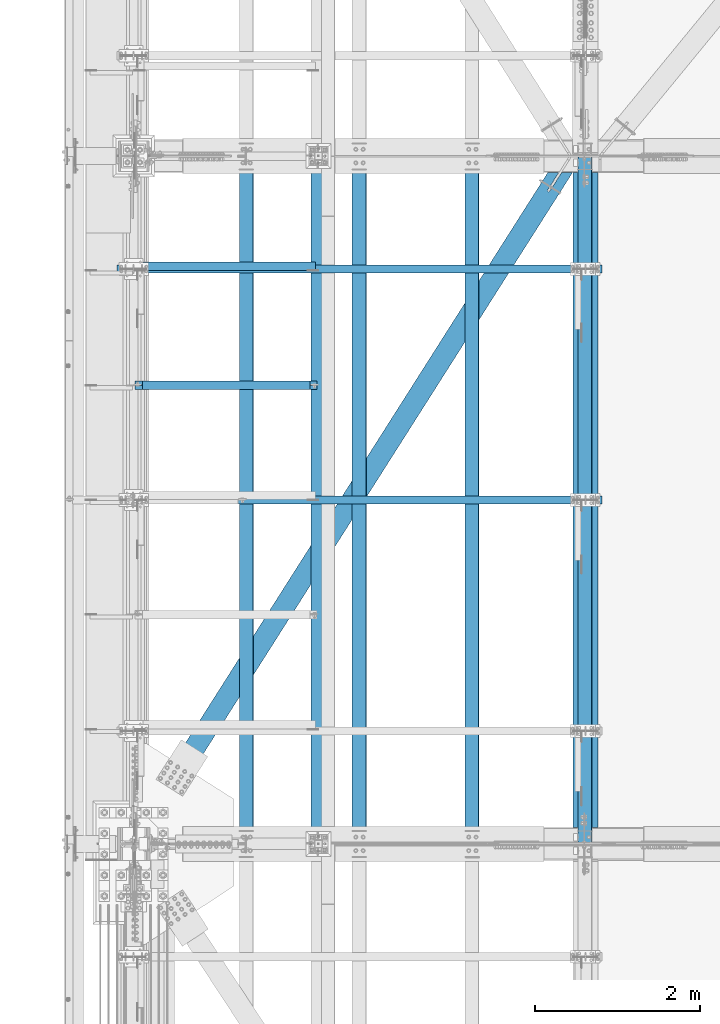
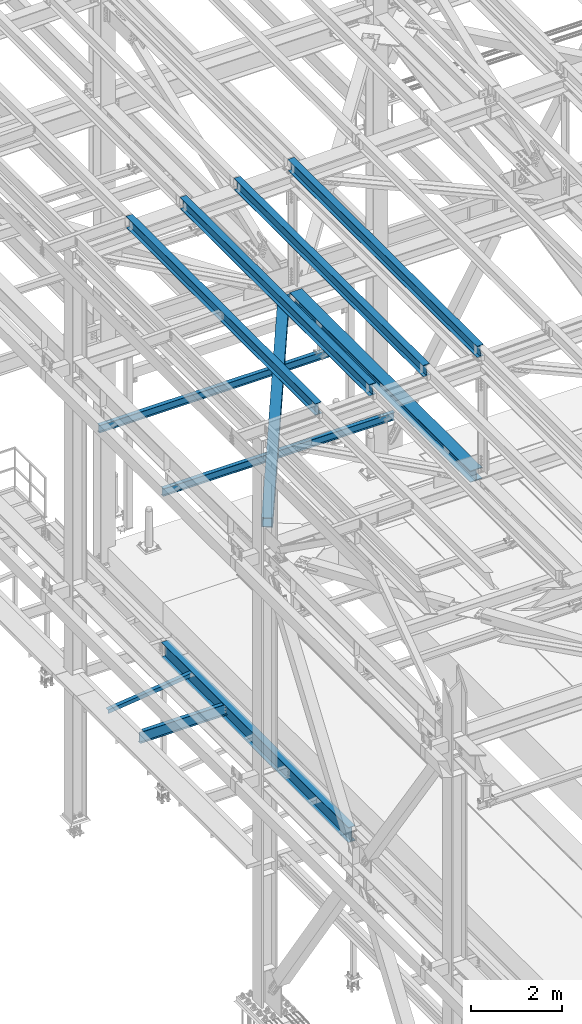
# One storey, part 1878 of 3843: 11 beams, 11 elements without a shape of their own.
"""IFC2X3 building model written with IfcOpenShell, lengths in millimetres."""

from ifc_helpers import new_model, si_unit, frame, origin_with_axes, place, context, subcontext, project, spatial, faceted_brep, material, type_object, element, aggregate, save


model = new_model("IFC2X3")

# Units and contexts
model_context = context("Model", 3, precision=1e-05, world=origin_with_axes())
body_context = subcontext(model_context, "Body", "Model", "MODEL_VIEW")
ifc_project = project(units=[si_unit("LENGTHUNIT", "METRE", prefix="MILLI"), si_unit("AREAUNIT", "SQUARE_METRE"), si_unit("VOLUMEUNIT", "CUBIC_METRE"), si_unit("MASSUNIT", "GRAM", prefix="KILO"), si_unit("TIMEUNIT", "SECOND"), si_unit("PLANEANGLEUNIT", "RADIAN"), si_unit("SOLIDANGLEUNIT", "STERADIAN"), si_unit("THERMODYNAMICTEMPERATUREUNIT", "DEGREE_CELSIUS"), si_unit("LUMINOUSINTENSITYUNIT", "LUMEN")], contexts=[model_context])

# Site, building, storey
site_placement = place(None, origin_with_axes())
site = spatial("IfcSite", under=ifc_project, at=site_placement, CompositionType="ELEMENT")
building_placement = place(site_placement, origin_with_axes())
building = spatial("IfcBuilding", under=site, at=building_placement, Name="Undefined", CompositionType="ELEMENT")
storey_placement = place(building_placement, origin_with_axes())
storey = spatial("IfcBuildingStorey", under=building, at=storey_placement, Name="Undefined", CompositionType="ELEMENT", Elevation=0.0)

# Assembly, beam
assembly_1_placement = place(storey_placement, origin_with_axes())
assembly_1 = element("IfcElementAssembly", 1, at=assembly_1_placement, inside=storey, Name="ANGLE", AssemblyPlace="NOTDEFINED", PredefinedType="RIGID_FRAME")
ifc_material_1 = material(Name="STEEL/A572-50")
beam_type_1 = type_object("IfcBeamType", Name="L4X4X3/8", PredefinedType="NOTDEFINED")
beam_1_placement = place(assembly_1_placement, frame((38788.5093206542, 82646.242188, 33960.1419503901), z_axis=(0.0, 1.0, 0.0), x_axis=(-0.993268693078032, 0.0, -0.115833084009098)))
beam_1 = element("IfcBeam", 2, at=beam_1_placement, type_object=beam_type_1, material=ifc_material_1, Name="ANGLE", ObjectType="L4X4X3/8", context=body_context, shape_type="Brep", body=[
    faceted_brep([(0.0, 50.8000000000029, -50.8000000000029), (0.0, 50.8000000000029, 50.8000000000029), (2192.8104802954, 50.7999999940694, 50.8000000000029), (2192.8104802954, 50.7999999940694, -50.8000000000029), (0.0, 41.2750000000015, 50.8000000000029), (2192.81048029537, 41.2749999940788, 50.8000000000029), (0.0, 41.2749999999942, -41.2750000000015), (2192.81048029537, 41.2749999940788, -41.2750000000015), (0.0, -50.8000000000029, -41.2750000000015), (2192.81048029512, -50.8000000058528, -41.2750000000015), (0.0, -50.8000000000029, -50.8000000000029), (2192.81048029512, -50.8000000058528, -50.8000000000029)], [[[0, 1, 2, 3]], [[1, 4, 5, 2]], [[4, 6, 7, 5]], [[6, 8, 9, 7]], [[8, 10, 11, 9]], [[10, 0, 3, 11]], [[5, 7, 9, 11, 3, 2]], [[10, 8, 6, 4, 1, 0]]]),
])
aggregate(assembly_1, [beam_1])

assembly_2_placement = place(storey_placement, origin_with_axes())
assembly_2 = element("IfcElementAssembly", 3, at=assembly_2_placement, inside=storey, Name="BEAM", AssemblyPlace="NOTDEFINED", PredefinedType="RIGID_FRAME")
ifc_material_2 = material(Name="STEEL/A992")
beam_type_2 = type_object("IfcBeamType", Name="W12X26", PredefinedType="NOTDEFINED")
beam_2_placement = place(assembly_2_placement, frame((42059.109262365, 75628.9369635993, 45716.1130341814), z_axis=(-0.021152098476392, 0.00280870100013271, 0.999772324046199), x_axis=(0.0, 0.9999960538275, -0.00280932899951577)))
beam_2 = element("IfcBeam", 4, at=beam_2_placement, type_object=beam_type_2, material=ifc_material_2, Name="BEAM", ObjectType="W12X26", context=body_context, shape_type="Brep", body=[
    faceted_brep([(12.7049554986879, 82.5499999998792, -155.575000000288), (12.678202521085, 82.5499999998865, -146.050000000272), (8343.91107898115, 82.5500000003303, -146.050000021387), (8343.93783195874, 82.5500000003303, -155.575000021403), (12.6734857853589, 3.17500000001746, -146.050000000272), (8343.90636224544, 3.17500000046857, -146.050000021402), (11.8530611392634, 3.17499999997381, 146.050000000214), (8343.08593759935, 3.17500000041764, 146.049999979092), (11.8577778749896, 82.549999999821, 146.050000000228), (8343.09065433506, 82.5500000002721, 146.049999979099), (11.8310248974012, 82.5499999998283, 155.575000000244), (8343.06390135747, 82.5500000002721, 155.574999979122), (11.8212140870892, -82.5499999998792, 155.575000000223), (8343.05409054716, -82.5499999994281, 155.574999979108), (11.8479670646775, -82.5499999998792, 146.050000000207), (8343.08084352475, -82.5499999994354, 146.049999979092), (11.8526838004036, -3.17500000001746, 146.050000000221), (8343.08556026047, -3.17499999956635, 146.049999979092), (12.6731084464991, -3.17499999996653, -146.050000000272), (8343.90595459306, -3.17500000061409, -146.050000012117), (12.668391710773, -82.549999999821, -146.050000000279), (8343.90125470564, -82.5500000264656, -146.05000001486), (12.6951446883613, -82.549999999821, -155.575000000303), (8343.92802114844, -82.5499999993772, -155.575000021418)], [[[0, 1, 2, 3]], [[1, 4, 5, 2]], [[4, 6, 7, 5]], [[6, 8, 9, 7]], [[8, 10, 11, 9]], [[10, 12, 13, 11]], [[12, 14, 15, 13]], [[14, 16, 17, 15]], [[16, 18, 19, 17]], [[18, 20, 21, 19]], [[20, 22, 23, 21]], [[22, 0, 3, 23]], [[5, 7, 9, 11, 13, 15, 17, 19, 21, 23, 3, 2]], [[22, 20, 18, 16, 14, 12, 10, 8, 6, 4, 1, 0]]]),
])
aggregate(assembly_2, [beam_2])

assembly_3_placement = place(storey_placement, origin_with_axes())
assembly_3 = element("IfcElementAssembly", 5, at=assembly_3_placement, inside=storey, Name="BEAM", AssemblyPlace="NOTDEFINED", PredefinedType="RIGID_FRAME")
beam_3_placement = place(assembly_3_placement, frame((40687.5092623181, 75628.8365619928, 45681.0385441754), z_axis=(-0.0211520975252424, 0.00216334199957782, 0.999773928806746), x_axis=(0.0, 0.999997658923617, -0.00216382699983441)))
beam_3 = element("IfcBeam", 6, at=beam_3_placement, type_object=beam_type_2, material=ifc_material_2, Name="BEAM", ObjectType="W12X26", context=body_context, shape_type="Brep", body=[
    faceted_brep([(12.7037963889888, 82.550000000585, -155.57500000039), (12.6832505025814, 82.550000000585, -146.050000000381), (8343.90271783868, 82.5500000001048, -146.049999994), (8343.92333463172, 82.5500000000757, -155.574999994024), (12.6795583240309, 3.17499999979918, -146.050000000425), (8343.8990829551, 3.17499999965366, -146.049999993877), (12.0476553013868, 3.1749999997046, 146.049999999872), (8343.26715921196, 3.17499999925349, 146.05000002106), (12.0512882621406, 82.5499999995445, 146.050000000134), (8343.27079217273, 82.5499999990934, 146.050000021336), (12.0306823729334, 82.5499999995372, 155.575000000128), (8343.25018628351, 82.5499999990861, 155.575000021316), (12.0231258145359, -82.5500000001484, 155.574999999561), (8343.24262972512, -82.5500000005923, 155.575000020763), (12.0437317037577, -82.5500000001266, 146.049999999581), (8343.26323561433, -82.5500000005777, 146.050000020783), (12.0473646645114, -3.1750000002794, 146.049999999843), (8343.26686857508, -3.17500000073051, 146.050000021038), (12.6792675333563, -3.17500000025029, -146.050000000425), (8343.89879216443, -3.17500000038126, -146.049999993869), (12.6756326497853, -82.5500000006869, -146.050000000301), (8343.89510752616, -82.549999962459, -146.049999975388), (12.6962628250476, -82.5500000003522, -155.574999999924), (8343.9157740739, -82.5500000008324, -155.574999993776)], [[[0, 1, 2, 3]], [[1, 4, 5, 2]], [[4, 6, 7, 5]], [[6, 8, 9, 7]], [[8, 10, 11, 9]], [[10, 12, 13, 11]], [[12, 14, 15, 13]], [[14, 16, 17, 15]], [[16, 18, 19, 17]], [[18, 20, 21, 19]], [[20, 22, 23, 21]], [[22, 0, 3, 23]], [[5, 7, 9, 11, 13, 15, 17, 19, 21, 23, 3, 2]], [[22, 20, 18, 16, 14, 12, 10, 8, 6, 4, 1, 0]]]),
])
aggregate(assembly_3, [beam_3])

assembly_4_placement = place(storey_placement, origin_with_axes())
assembly_4 = element("IfcElementAssembly", 7, at=assembly_4_placement, inside=storey, Name="BEAM", AssemblyPlace="NOTDEFINED", PredefinedType="RIGID_FRAME")
beam_4_placement = place(assembly_4_placement, frame((39315.9092622757, 75628.7302773272, 45645.6479519217), z_axis=(-0.0211520981891954, 0.00148016899947834, 0.999775173647519), x_axis=(0.0, 0.999998904059274, -0.00148050000008735)))
beam_4 = element("IfcBeam", 8, at=beam_4_placement, type_object=beam_type_2, material=ifc_material_2, Name="BEAM", ObjectType="W12X26", context=body_context, shape_type="Brep", body=[
    faceted_brep([(12.7025516291906, 82.5499999997046, -155.57499999999), (12.6885003375937, 82.5499999996755, -146.050000000127), (8343.89766409336, 82.5499999999156, -146.050000026808), (8343.91172958676, 82.5500000001412, -155.575000022633), (12.6860146524414, 3.17499999982829, -146.05000000001), (8343.8951452786, 3.17500000030122, -146.050000022522), (12.2536568804207, 3.17500000016298, 146.049999999945), (8343.46278750656, 3.17500000063592, 146.049999977447), (12.2561425655731, 82.5500000000102, 146.049999999836), (8343.46527319174, 82.5500000004831, 146.049999977331), (12.2420439425769, 82.5500000000247, 155.574999999837), (8343.45117456872, 82.5500000004904, 155.574999977325), (12.2368737174402, -82.5499999996609, 155.575000000063), (8343.44600434358, -82.549999999188, 155.574999977573), (12.2509723404364, -82.5499999996682, 146.050000000068), (8343.46010296659, -82.5499999991953, 146.049999977564), (12.2534580256033, -3.17499999982101, 146.049999999959), (8343.46258865176, -3.17499999934807, 146.049999977462), (12.6858157976094, -3.17500000015571, -146.050000000003), (8343.89494642378, -3.17499999968277, -146.050000022515), (12.683330112457, -82.5500000000029, -146.049999999894), (8343.89243466449, -82.5500000001557, -146.049999991803), (12.697475105073, -82.5499999999811, -155.575000000317), (8343.90655936163, -82.5499999995518, -155.575000022392)], [[[0, 1, 2, 3]], [[1, 4, 5, 2]], [[4, 6, 7, 5]], [[6, 8, 9, 7]], [[8, 10, 11, 9]], [[10, 12, 13, 11]], [[12, 14, 15, 13]], [[14, 16, 17, 15]], [[16, 18, 19, 17]], [[18, 20, 21, 19]], [[20, 22, 23, 21]], [[22, 0, 3, 23]], [[5, 7, 9, 11, 13, 15, 17, 19, 21, 23, 3, 2]], [[22, 20, 18, 16, 14, 12, 10, 8, 6, 4, 1, 0]]]),
])
aggregate(assembly_4, [beam_4])

assembly_5_placement = place(storey_placement, origin_with_axes())
assembly_5 = element("IfcElementAssembly", 9, at=assembly_5_placement, inside=storey, Name="BEAM", AssemblyPlace="NOTDEFINED", PredefinedType="RIGID_FRAME")
beam_5_placement = place(assembly_5_placement, frame((37944.3092623314, 75628.6181098749, 45609.9412422812), z_axis=(-0.0211520981056674, 0.000759183000074701, 0.999775981101217), x_axis=(0.0, 0.999999711691469, -0.000759352999765827)))
beam_5 = element("IfcBeam", 10, at=beam_5_placement, type_object=beam_type_2, material=ifc_material_2, Name="BEAM", ObjectType="W12X26", context=body_context, shape_type="Brep", body=[
    faceted_brep([(12.7013527714444, 82.5499999995736, -155.575000000172), (12.6940983892127, 82.5500000000175, -146.049999999719), (8343.89650247573, 82.5500000000829, -146.050000009884), (8343.90373166696, 82.5500000005341, -155.575000023688), (12.6928234748339, 3.17500000015571, -146.049999999726), (8343.89522553135, 3.17500000065775, -146.050000023708), (12.4710660237906, 3.17499999984284, 146.049999999668), (8343.67346808031, 3.17500000034488, 146.049999975687), (12.4723409381841, 82.54999999969, 146.049999999668), (8343.6747429947, 82.5500000001994, 146.049999975687), (12.4651097169553, 82.5499999996828, 155.574999999655), (8343.66751177347, 82.5500000001848, 155.574999975666), (12.462457895017, -82.5500000000175, 155.574999999648), (8343.66485995153, -82.5499999995154, 155.574999975666), (12.4696891162457, -82.5500000000175, 146.049999999661), (8343.67209117276, -82.5499999995081, 146.049999975679), (12.4709640306392, -3.17500000015571, 146.049999999668), (8343.67336608715, -3.17499999965366, 146.049999975687), (12.6927214816824, -3.17499999983556, -146.049999999726), (8343.89517244208, -3.17500000062137, -146.04999998409), (12.6914465672889, -82.54999999969, -146.049999999719), (8343.89384245234, -82.5500000222601, -146.049999986732), (12.6986547122506, -82.5500000001193, -155.57500000031), (8343.90111169781, -82.5500000007087, -155.574999982418)], [[[0, 1, 2, 3]], [[1, 4, 5, 2]], [[4, 6, 7, 5]], [[6, 8, 9, 7]], [[8, 10, 11, 9]], [[10, 12, 13, 11]], [[12, 14, 15, 13]], [[14, 16, 17, 15]], [[16, 18, 19, 17]], [[18, 20, 21, 19]], [[20, 22, 23, 21]], [[22, 0, 3, 23]], [[5, 7, 9, 11, 13, 15, 17, 19, 21, 23, 3, 2]], [[22, 20, 18, 16, 14, 12, 10, 8, 6, 4, 1, 0]]]),
])
aggregate(assembly_5, [beam_5])

assembly_6_placement = place(storey_placement, origin_with_axes())
assembly_6 = element("IfcElementAssembly", 11, at=assembly_6_placement, inside=storey, Name="BEAM", AssemblyPlace="NOTDEFINED", PredefinedType="RIGID_FRAME")
beam_type_3 = type_object("IfcBeamType", Name="W8X13", PredefinedType="NOTDEFINED")
beam_6_placement = place(assembly_6_placement, frame((36372.8, 79806.8, 41402.0), z_axis=(0.0, 0.0, 1.0), x_axis=(1.0, 0.0, 0.0)))
beam_6 = element("IfcBeam", 12, at=beam_6_placement, type_object=beam_type_3, material=ifc_material_2, Name="BEAM", ObjectType="W8X13", context=body_context, shape_type="Brep", body=[
    faceted_brep([(0.0, 50.7999999999993, -101.599999999999), (0.0, 50.7999999999993, -95.25), (5892.8, 50.7999999999993, -95.25), (5892.8, 50.7999999999993, -101.599999999999), (0.0, 3.17499999999927, -95.25), (5892.8, 3.17499999999927, -95.25), (-2.44140610448085e-05, 3.17500000000291, 95.2499999999927), (5892.8, 3.17499999999927, 95.25), (0.0, 50.7999999999993, 95.25), (5892.8, 50.7999999999993, 95.25), (0.0, 50.7999999999993, 101.599999999999), (5892.8, 50.7999999999993, 101.599999999999), (0.0, -50.7999999999993, 101.599999999999), (5892.8, -50.7999999999993, 101.599999999999), (0.0, -50.7999999999993, 95.25), (5892.8, -50.7999999999993, 95.25), (0.0, -3.17499999999927, 95.25), (5892.8, -3.17499999999927, 95.25), (0.0, -3.17499999999927, -95.25), (5892.8, -3.17499999999927, -95.25), (0.0, -50.7999999999993, -95.25), (5892.8, -50.7999999999993, -95.25), (0.0, -50.7999999999993, -101.599999999999), (5892.8, -50.7999999999993, -101.599999999999)], [[[0, 1, 2, 3]], [[1, 4, 5, 2]], [[4, 6, 7, 5]], [[6, 8, 9, 7]], [[8, 10, 11, 9]], [[10, 12, 13, 11]], [[12, 14, 15, 13]], [[14, 16, 17, 15]], [[16, 18, 19, 17]], [[18, 20, 21, 19]], [[20, 22, 23, 21]], [[22, 0, 3, 23]], [[5, 7, 9, 11, 13, 15, 17, 19, 21, 23, 3, 2]], [[22, 20, 18, 16, 14, 12, 10, 8, 6, 4, 1, 0]]]),
])
aggregate(assembly_6, [beam_6])

assembly_7_placement = place(storey_placement, origin_with_axes())
assembly_7 = element("IfcElementAssembly", 13, at=assembly_7_placement, inside=storey, Name="BEAM", AssemblyPlace="NOTDEFINED", PredefinedType="RIGID_FRAME")
beam_7_placement = place(assembly_7_placement, frame((36372.8, 82613.5, 41402.0), z_axis=(0.0, 0.0, 1.0), x_axis=(1.0, 0.0, 0.0)))
beam_7 = element("IfcBeam", 14, at=beam_7_placement, type_object=beam_type_3, material=ifc_material_2, Name="BEAM", ObjectType="W8X13", context=body_context, shape_type="Brep", body=[
    faceted_brep([(0.0, 50.7999999999993, -101.599999999999), (0.0, 50.7999999999993, -95.25), (5892.8, 50.7999999999993, -95.25), (5892.8, 50.7999999999993, -101.599999999999), (0.0, 3.17499999999927, -95.25), (5892.8, 3.17499999999927, -95.25), (-2.44140610448085e-05, 3.17500000000291, 95.2499999999927), (5892.8, 3.17499999999927, 95.25), (0.0, 50.7999999999993, 95.25), (5892.8, 50.7999999999993, 95.25), (0.0, 50.7999999999993, 101.599999999999), (5892.8, 50.7999999999993, 101.599999999999), (0.0, -50.7999999999993, 101.599999999999), (5892.8, -50.7999999999993, 101.599999999999), (0.0, -50.7999999999993, 95.25), (5892.8, -50.7999999999993, 95.25), (0.0, -3.17499999999927, 95.25), (5892.8, -3.17499999999927, 95.25), (0.0, -3.17499999999927, -95.25), (5892.8, -3.17499999999927, -95.25), (0.0, -50.7999999999993, -95.25), (5892.8, -50.7999999999993, -95.25), (0.0, -50.7999999999993, -101.599999999999), (5892.8, -50.7999999999993, -101.599999999999)], [[[0, 1, 2, 3]], [[1, 4, 5, 2]], [[4, 6, 7, 5]], [[6, 8, 9, 7]], [[8, 10, 11, 9]], [[10, 12, 13, 11]], [[12, 14, 15, 13]], [[14, 16, 17, 15]], [[16, 18, 19, 17]], [[18, 20, 21, 19]], [[20, 22, 23, 21]], [[22, 0, 3, 23]], [[5, 7, 9, 11, 13, 15, 17, 19, 21, 23, 3, 2]], [[22, 20, 18, 16, 14, 12, 10, 8, 6, 4, 1, 0]]]),
])
aggregate(assembly_7, [beam_7])

assembly_8_placement = place(storey_placement, origin_with_axes())
assembly_8 = element("IfcElementAssembly", 15, at=assembly_8_placement, inside=storey, AssemblyPlace="NOTDEFINED", PredefinedType="RIGID_FRAME")
ifc_material_3 = material()
beam_type_4 = type_object("IfcBeamType", Name="HSS10X10X3/4", PredefinedType="NOTDEFINED")
beam_8_placement = place(assembly_8_placement, frame((36576.0, 75628.5, 42246.55), z_axis=(0.844083796719708, -0.536211286821941, 0.0), x_axis=(0.536211309998024, 0.844083781996908, 0.0)))
beam_8 = element("IfcBeam", 16, at=beam_8_placement, type_object=beam_type_4, material=ifc_material_3, ObjectType="HSS10X10X3/4", context=body_context, shape_type="Brep", body=[
    faceted_brep([(9656.0334554301, -127.0, -14.2875066509878), (9656.0334554301, -107.949999999997, -14.2875066509878), (9403.62095610797, -107.949999999997, -14.2875136598741), (9403.62095610797, -127.0, -14.2875136598741), (9398.15336637764, -107.949999999997, -13.1999425975082), (9398.15336637764, -127.0, -13.1999425975082), (9393.51816756405, -107.949999999997, -10.1028019430596), (9393.51816756405, -127.0, -10.1028019430596), (9390.42102667221, -107.949999999997, -5.46760328808159), (9390.42102667221, -127.0, -5.46760328808159), (9389.33345532982, -107.949999999997, -1.43763463711366e-05), (9389.33345532982, -127.0, -1.43763463711366e-05), (9390.421026404, -107.949999999997, 5.46757532078482), (9390.421026404, -127.0, 5.46757532078482), (9393.51816704663, -107.949999999997, 10.1027741058715), (9393.51816704663, -127.0, 10.1027741058715), (9398.1533656731, -107.949999999997, 13.1999149858966), (9398.1533656731, -127.0, 13.1999149858966), (9403.62095531452, -107.949999999997, 14.2874863400939), (9403.62095531452, -127.0, 14.2874863400939), (9674.18596335511, -127.0, 14.2874938529858), (9674.18596335511, -107.949999999997, 14.2874938529858), (9656.0334554301, 107.949999999997, -14.2875066509878), (9656.0334554301, 127.0, -14.2875066509878), (9403.62095610797, 127.0, -14.2875136598741), (9403.62095610797, 107.949999999997, -14.2875136598741), (9398.15336637764, 127.0, -13.1999425975082), (9398.15336637764, 107.949999999997, -13.1999425975082), (9393.51816756405, 127.0, -10.1028019430596), (9393.51816756405, 107.949999999997, -10.1028019430596), (9390.42102667221, 127.0, -5.46760328808159), (9390.42102667221, 107.949999999997, -5.46760328808159), (9389.33345532982, 127.0, -1.43763463711366e-05), (9389.33345532982, 107.949999999997, -1.43763463711366e-05), (9390.421026404, 127.0, 5.46757532078482), (9390.421026404, 107.949999999997, 5.46757532078482), (9393.51816704663, 127.0, 10.1027741058715), (9393.51816704663, 107.949999999997, 10.1027741058715), (9398.1533656731, 127.0, 13.1999149858966), (9398.1533656731, 107.949999999997, 13.1999149858966), (9403.62095531452, 127.0, 14.2874863400939), (9403.62095531452, 107.949999999997, 14.2874863400939), (9674.18596335511, 107.949999999997, 14.2874938529858), (9674.18596335511, 127.0, 14.2874938529858), (1125.2280481208, 26.9874999999956, -107.949999998387), (1125.22804812068, 26.9874999999956, -126.999999998354), (1377.64054776057, 26.9874999999956, -126.999999998023), (1377.64054776079, 26.9874999999956, -107.94999999806), (1383.10813744651, 25.8999287917104, -126.999999998023), (1383.10813744672, 25.8999287917104, -107.949999998045), (1387.74333616659, 22.8027880244699, -126.999999998012), (1387.74333616679, 22.8027880244699, -107.949999998042), (1390.84047693385, 18.167589304423, -126.999999998008), (1390.84047693407, 18.167589304423, -107.949999998045), (1391.92804814216, 12.6999996185259, -126.999999998012), (1391.92804814235, 12.6999996185259, -107.949999998042), (1390.84047693385, 7.23241069557116, -126.999999998008), (1390.84047693407, 7.23241069557116, -107.949999998045), (1387.74333616659, 2.59721197552426, -126.999999998012), (1387.74333616679, 2.59721197552426, -107.949999998042), (1383.10813744651, -0.499928791716229, -126.999999998023), (1383.10813744672, -0.499928791716229, -107.949999998045), (1377.64054776057, -1.58750000000146, -126.999999998023), (1377.64054776079, -1.58750000000146, -107.94999999806), (1125.22804812068, -1.58750000000146, -126.999999998354), (1125.2280481208, -1.58750000000146, -107.949999998387), (9596.53357362878, -107.949999999997, -107.949999981545), (1125.22804774128, -107.949999999997, -107.949999997691), (1125.22804774129, -107.949999999997, 107.950000001991), (9733.68585330987, -107.949999999997, 107.950000018391), (1125.22804774128, 107.949999999997, -107.949999997691), (9596.53357362878, 107.949999999997, -107.949999981545), (1383.10813744931, -0.499928791716229, 127.000000001563), (1383.1081374491, -0.499928791716229, 107.950000001603), (1377.64054776318, -1.58750000000146, 107.950000001596), (1377.64054776338, -1.58750000000146, 127.000000001563), (1387.7433361694, 2.59721197552426, 127.000000001581), (1387.74333616918, 2.59721197552426, 107.950000001611), (1390.84047693665, 7.23241069557116, 127.000000001577), (1390.84047693643, 7.23241069557116, 107.950000001618), (1391.92804814494, 12.6999996185259, 127.000000001588), (1391.92804814473, 12.6999996185259, 107.950000001614), (1390.84047693665, 18.167589304423, 127.000000001577), (1390.84047693643, 18.167589304423, 107.950000001618), (1387.7433361694, 22.8027880244699, 127.000000001581), (1387.74333616918, 22.8027880244699, 107.950000001611), (1383.10813744931, 25.8999287917104, 127.000000001563), (1383.1081374491, 25.8999287917104, 107.950000001603), (1377.64054776338, 26.9874999999956, 127.000000001563), (1377.64054776318, 26.9874999999956, 107.950000001596), (1125.22804812223, 26.9874999999956, 127.000000001239), (1125.22804812211, 26.9874999999956, 107.950000001269), (1125.22804774128, 127.0, 127.000000001965), (1125.22804774128, 127.0, -126.999999997657), (1125.22804774129, 107.949999999997, 107.950000001991), (1125.22804812211, -1.58750000000146, 107.950000001269), (9733.68585330987, 107.949999999997, 107.950000018391), (1125.22804812223, -1.58750000000146, 127.000000001239), (1125.22804774128, -127.0, -126.999999997657), (1125.22804774128, -127.0, 127.000000001965), (9745.78752504644, -127.0, 127.000000018394), (9745.78752504644, 127.0, 127.000000018394), (9584.43190189222, 127.0, -126.999999981541), (9584.43190189222, -127.0, -126.999999981541)], [[[0, 1, 2, 3]], [[3, 2, 4, 5]], [[5, 4, 6, 7]], [[7, 6, 8, 9]], [[9, 8, 10, 11]], [[11, 10, 12, 13]], [[13, 12, 14, 15]], [[15, 14, 16, 17]], [[17, 16, 18, 19]], [[20, 19, 18, 21]], [[22, 23, 24, 25]], [[25, 24, 26, 27]], [[27, 26, 28, 29]], [[29, 28, 30, 31]], [[31, 30, 32, 33]], [[33, 32, 34, 35]], [[35, 34, 36, 37]], [[37, 36, 38, 39]], [[39, 38, 40, 41]], [[42, 41, 40, 43]], [[44, 45, 46, 47]], [[47, 46, 48, 49]], [[49, 48, 50, 51]], [[51, 50, 52, 53]], [[53, 52, 54, 55]], [[55, 54, 56, 57]], [[57, 56, 58, 59]], [[59, 58, 60, 61]], [[61, 60, 62, 63]], [[63, 62, 64, 65]], [[16, 14, 12, 10, 8, 6, 4, 2, 1, 66, 67, 68, 69, 21, 18]], [[70, 44, 47, 49, 51, 53, 55, 57, 59, 61, 63, 65, 67, 66, 71]], [[72, 73, 74, 75]], [[76, 77, 73, 72]], [[78, 79, 77, 76]], [[80, 81, 79, 78]], [[82, 83, 81, 80]], [[84, 85, 83, 82]], [[86, 87, 85, 84]], [[88, 89, 87, 86]], [[90, 91, 89, 88]], [[92, 93, 45, 44, 70, 94, 91, 90]], [[68, 95, 74, 73, 77, 79, 81, 83, 85, 87, 89, 91, 94, 96, 69]], [[75, 74, 95, 97]], [[68, 67, 65, 64, 98, 99, 97, 95]], [[92, 90, 88, 86, 84, 82, 80, 78, 76, 72, 75, 97, 99, 100, 101]], [[69, 96, 42, 43, 101, 100, 20, 21]], [[38, 36, 34, 32, 30, 28, 26, 24, 23, 102, 93, 92, 101, 43, 40]], [[98, 64, 62, 60, 58, 56, 54, 52, 50, 48, 46, 45, 93, 102, 103]], [[100, 99, 98, 103, 0, 3, 5, 7, 9, 11, 13, 15, 17, 19, 20]], [[103, 102, 23, 22, 71, 66, 1, 0]], [[96, 94, 70, 71, 22, 25, 27, 29, 31, 33, 35, 37, 39, 41, 42]]]),
])
aggregate(assembly_8, [beam_8])

assembly_9_placement = place(storey_placement, origin_with_axes())
assembly_9 = element("IfcElementAssembly", 17, at=assembly_9_placement, inside=storey, Name="BEAM", AssemblyPlace="NOTDEFINED", PredefinedType="RIGID_FRAME")
beam_type_5 = type_object("IfcBeamType", Name="W12X65", PredefinedType="NOTDEFINED")
beam_9_placement = place(assembly_9_placement, frame((42062.4, 75628.4999999989, 42272.661883859), z_axis=(0.0, 0.00280790599950705, 0.999996057824179), x_axis=(0.0, 0.999996057824179, -0.00280790599950644)))
beam_9 = element("IfcBeam", 18, at=beam_9_placement, type_object=beam_type_5, material=ifc_material_2, Name="BEAM", ObjectType="W12X65", context=body_context, shape_type="Brep", body=[
    faceted_brep([(198.870666410876, 152.400000000001, -153.987499999428), (198.826090727409, 152.400000000001, -138.112499999486), (8158.58246954666, 152.400000000001, -138.112499998249), (8158.62704523013, 152.400000000001, -153.987499998191), (198.826090727409, 4.76249999999709, -138.112499999486), (8158.58246954666, 4.76249999999709, -138.112499998249), (198.050473835057, 4.76249999999709, 138.112499999552), (8157.80685265434, 4.76249999999709, 138.112500000781), (198.050473835057, 152.400000000001, 138.112499999552), (8157.80685265434, 152.400000000001, 138.112500000781), (198.00589815159, 152.400000000001, 153.987499999494), (8157.76227697085, 152.400000000001, 153.987500000723), (198.00589815159, -152.400000000001, 153.987499999494), (8157.76227697085, -152.400000000001, 153.987500000723), (198.050473835057, -152.400000000001, 138.112499999552), (8157.80685265434, -152.400000000001, 138.112500000781), (198.050473835057, -4.76249999999709, 138.112499999552), (8157.80685265434, -4.76249999999709, 138.112500000781), (198.826090727409, -4.76249999999709, -138.112499999486), (8158.58246954666, -4.76249999999709, -138.112499998249), (198.826090727409, -152.400000000001, -138.112499999486), (8158.58246954666, -152.400000000001, -138.112499998249), (198.870666410876, -152.400000000001, -153.987499999428), (8158.62704523013, -152.400000000001, -153.987499998191)], [[[0, 1, 2, 3]], [[1, 4, 5, 2]], [[4, 6, 7, 5]], [[6, 8, 9, 7]], [[8, 10, 11, 9]], [[10, 12, 13, 11]], [[12, 14, 15, 13]], [[14, 16, 17, 15]], [[16, 18, 19, 17]], [[18, 20, 21, 19]], [[20, 22, 23, 21]], [[22, 0, 3, 23]], [[5, 7, 9, 11, 13, 15, 17, 19, 21, 23, 3, 2]], [[22, 20, 18, 16, 14, 12, 10, 8, 6, 4, 1, 0]]]),
])
aggregate(assembly_9, [beam_9])

assembly_10_placement = place(storey_placement, origin_with_axes())
assembly_10 = element("IfcElementAssembly", 19, at=assembly_10_placement, inside=storey, Name="BEAM", AssemblyPlace="NOTDEFINED", PredefinedType="RIGID_FRAME")
beam_type_6 = type_object("IfcBeamType", Name="W16X40", PredefinedType="NOTDEFINED")
beam_10_placement = place(assembly_10_placement, frame((38820.725, 75628.5, 33832.8), z_axis=(0.0, 0.0, 1.0), x_axis=(0.0, 1.0, 0.0)))
beam_10 = element("IfcBeam", 20, at=beam_10_placement, type_object=beam_type_6, material=ifc_material_2, Name="BEAM", ObjectType="W16X40", context=body_context, shape_type="Brep", body=[
    faceted_brep([(63.4999999999854, -88.9000000000015, -203.199999999997), (63.4999999999854, 88.9000000000015, -203.199999999997), (8293.09999999999, 88.9000000000015, -203.199999999997), (8293.09999999999, -88.9000000000015, -203.199999999997), (63.4999999999854, -88.9000000000015, -190.5), (63.4999999999854, -3.96875, -190.5), (63.4999999999854, -3.96875, 190.5), (63.4999999999854, -88.9000000000015, 190.5), (63.4999999999854, -88.9000000000015, 203.199999999997), (63.4999999999854, 88.9000000000015, 203.199999999997), (63.4999999999854, 88.9000000000015, 190.5), (63.4999999999854, 3.96875, 190.5), (63.4999999999854, 3.96875, -190.5), (63.4999999999854, 88.9000000000015, -190.5), (8293.09999999999, -88.9000000000015, -190.5), (8293.09999999999, -3.96875, -190.5), (8293.09999999999, -3.96875, 190.5), (8293.09999999999, -88.9000000000015, 190.5), (8293.09999999999, -88.9000000000015, 203.199999999997), (8293.09999999999, 88.9000000000015, 203.199999999997), (8293.09999999999, 88.9000000000015, 190.5), (8293.09999999999, 3.96875, 190.5), (8293.09999999999, 3.96875, -190.5), (8293.09999999999, 88.9000000000015, -190.5)], [[[0, 1, 2, 3]], [[0, 4, 5, 6, 7, 8, 9, 10, 11, 12, 13, 1]], [[5, 4, 14, 15]], [[6, 5, 15, 16]], [[7, 6, 16, 17]], [[8, 7, 17, 18]], [[9, 8, 18, 19]], [[10, 9, 19, 20]], [[11, 10, 20, 21]], [[12, 11, 21, 22]], [[13, 12, 22, 23]], [[1, 13, 23, 2]], [[22, 21, 20, 19, 18, 17, 16, 15, 14, 3, 2, 23]], [[4, 0, 3, 14]]]),
])
aggregate(assembly_10, [beam_10])

assembly_11_placement = place(storey_placement, origin_with_axes())
assembly_11 = element("IfcElementAssembly", 21, at=assembly_11_placement, inside=storey, Name="BEAM", AssemblyPlace="NOTDEFINED", PredefinedType="RIGID_FRAME")
beam_type_7 = type_object("IfcBeamType", Name="W12X14", PredefinedType="NOTDEFINED")
beam_11_placement = place(assembly_11_placement, frame((36576.0, 81199.434376, 33885.1875), z_axis=(0.0, 0.0, 1.0), x_axis=(1.0, 0.0, 0.0)))
beam_11 = element("IfcBeam", 22, at=beam_11_placement, type_object=beam_type_7, material=ifc_material_2, Name="BEAM", ObjectType="W12X14", context=body_context, shape_type="Brep", body=[
    faceted_brep([(92.8687501907334, -2.38125000000582, 125.412499999991), (92.8687501907334, 2.38125000000582, 125.412499999991), (16.6687499999971, 2.38125000000582, 125.412499999991), (16.6687499999971, -2.38125000000582, 125.412499999991), (97.7288297087798, -2.38125000000582, 126.379229922582), (97.7288297087798, 2.38125000000582, 126.379229922582), (101.849006176933, -2.38125000000582, 129.132243823056), (101.849006176933, 2.38125000000582, 129.132243823056), (104.602020077407, -2.38125000000582, 133.25242029121), (104.602020077407, 2.38125000000582, 133.25242029121), (105.568749999999, -2.38125000000582, 138.112499809256), (105.568749999999, 2.38125000000582, 138.112499809256), (105.568749999999, -50.8000000000029, 150.812499810811), (105.568749999999, 50.8000000000029, 150.8125), (105.568749999999, 50.8000000000029, 144.462500000001), (105.568749999999, 2.38125000000582, 144.462500000001), (105.568749999999, -2.38125000000582, 144.462500000001), (105.568749999999, -50.8000000000029, 144.462500000001), (16.6687499999971, -2.38125000000582, -144.462500000001), (16.6687499999971, -50.7999999999993, -144.462500000001), (2228.05625, -50.8000000000029, -144.462500000001), (2228.05625, -2.38125000000582, -144.462500000001), (16.6687499999971, -50.8000000000029, -150.8125), (2228.05625, -50.8000000000029, -150.8125), (16.6687499999971, 50.8000000000029, -150.8125), (2228.05625, 50.8000000000029, -150.8125), (16.6687499999971, 50.7999999999993, -144.462500000001), (2228.05625, 50.8000000000029, -144.462500000001), (16.6687499999971, 2.38125000000582, -144.462500000001), (2228.05625, 2.38125000000582, -144.462500000001), (2228.05625, 2.38125000000582, -117.887499999997), (2228.05625, 2.38125000000582, 112.712500000001), (2228.05625, 2.38125000000582, 125.412499999991), (2228.05625, -2.38125000000582, 125.412499999991), (2151.85624980927, 2.38125000000582, 125.412499999991), (2151.85624980927, -2.38125000000582, 125.412499999991), (2146.99617029122, 2.38125000000582, 126.379229922582), (2146.99617029122, -2.38125000000582, 126.379229922582), (2142.87599382307, 2.38125000000582, 129.132243823056), (2142.87599382307, -2.38125000000582, 129.132243823056), (2140.12297992259, 2.38125000000582, 133.25242029121), (2140.12297992259, -2.38125000000582, 133.25242029121), (2139.15625, 2.38125000000582, 138.112499809256), (2139.15625, -2.38125000000582, 138.112499809256), (2139.15625, -50.8000000000029, 150.8125), (2139.15625, -50.8000000000029, 144.462500000001), (2139.15625, -2.38125000000582, 144.462500000001), (2139.15625, 2.38125000000582, 144.462500000001), (2139.15625, 50.8000000000029, 144.462500000001), (2139.15625, 50.8000000000029, 150.8125), (16.6687499999971, 2.38125000000582, 112.712500000001), (16.6687499999971, 2.38125000000582, -117.887499999997)], [[[0, 1, 2, 3]], [[4, 5, 1, 0]], [[6, 7, 5, 4]], [[8, 9, 7, 6]], [[10, 11, 9, 8]], [[12, 13, 14, 15, 11, 10, 16, 17]], [[18, 19, 20, 21]], [[19, 22, 23, 20]], [[22, 24, 25, 23]], [[24, 26, 27, 25]], [[26, 28, 29, 27]], [[21, 20, 23, 25, 27, 29, 30, 31, 32, 33]], [[33, 32, 34, 35]], [[35, 34, 36, 37]], [[37, 36, 38, 39]], [[39, 38, 40, 41]], [[41, 40, 42, 43]], [[44, 45, 46, 43, 42, 47, 48, 49]], [[45, 44, 12, 17]], [[46, 45, 17, 16]], [[8, 6, 4, 0, 3, 18, 21, 33, 35, 37, 39, 41, 43, 46, 16, 10]], [[50, 51, 28, 26, 24, 22, 19, 18, 3, 2]], [[47, 42, 40, 38, 36, 34, 32, 31, 30, 29, 28, 51, 50, 2, 1, 5, 7, 9, 11, 15]], [[48, 47, 15, 14]], [[49, 48, 14, 13]], [[44, 49, 13, 12]]]),
])
aggregate(assembly_11, [beam_11])

save(model, "model.ifc")
